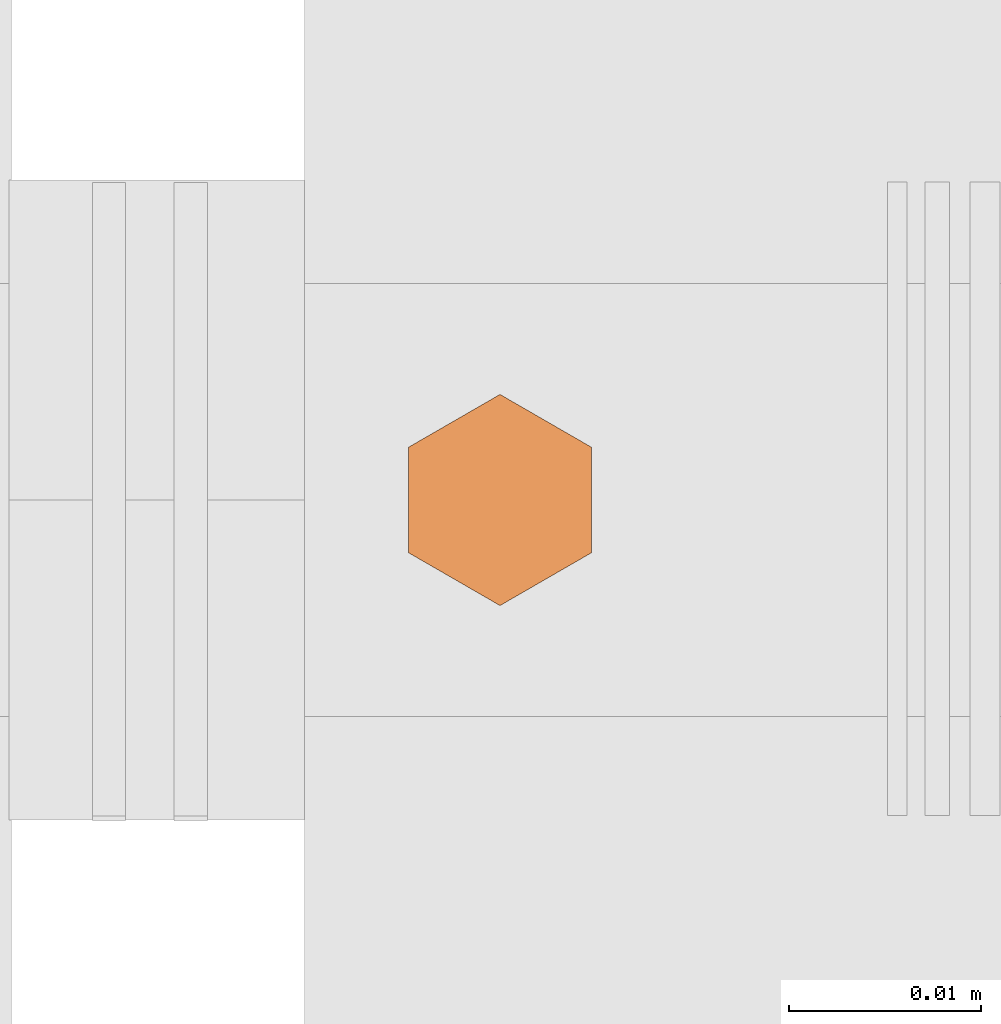
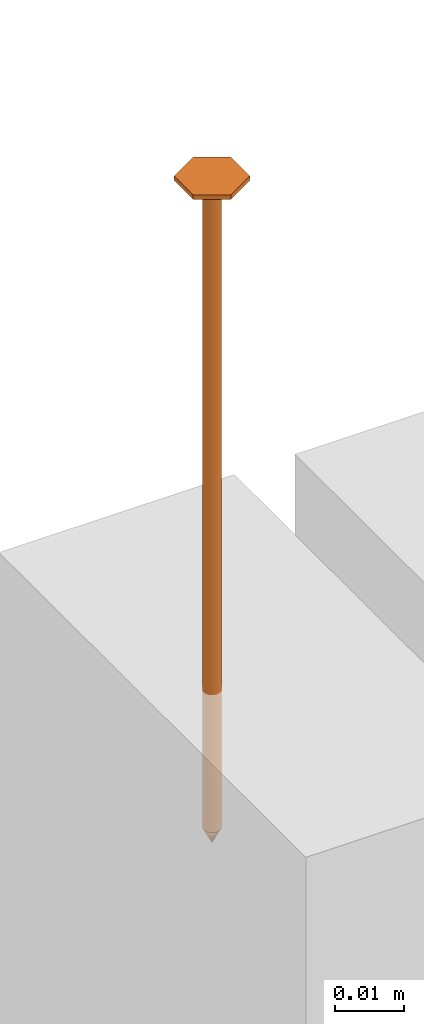
# One storey, part 23 of 44: 1 proxy.
"""IFC4 building model written with IfcOpenShell, lengths in feet."""

from ifc_helpers import new_model, entity, si_unit, converted_unit, derived_unit, direction, frame, origin, place, context, subcontext, project, spatial, source, transform, mapped, material, type_object, type_shapes, element, save


model = new_model("IFC4")

# Units and contexts
model_context = context("Model", 3, precision=0.0001, world=origin(), true_north=direction((6.12303176911189e-17, 1.0)))
body_context = subcontext(model_context, "Body", "Model", "MODEL_VIEW")
ifc_project = project(units=[converted_unit("LENGTHUNIT", "FOOT", entity("IfcRatioMeasure", 0.3048), si_unit("LENGTHUNIT", "METRE"), dimensions=[1, 0, 0, 0, 0, 0, 0]), converted_unit("AREAUNIT", "SQUARE FOOT", entity("IfcRatioMeasure", 0.09290304), si_unit("AREAUNIT", "SQUARE_METRE"), dimensions=[2, 0, 0, 0, 0, 0, 0]), converted_unit("VOLUMEUNIT", "CUBIC FOOT", entity("IfcRatioMeasure", 0.028316846592), si_unit("VOLUMEUNIT", "CUBIC_METRE"), dimensions=[3, 0, 0, 0, 0, 0, 0]), converted_unit("PLANEANGLEUNIT", "DEGREE", entity("IfcRatioMeasure", 0.0174532925199433), si_unit("PLANEANGLEUNIT", "RADIAN"), dimensions=[0, 0, 0, 0, 0, 0, 0]), si_unit("MASSUNIT", "GRAM", prefix="KILO"), derived_unit("MASSDENSITYUNIT", [(si_unit("MASSUNIT", "GRAM", prefix="KILO"), 1), (si_unit("LENGTHUNIT", "METRE"), -3)]), derived_unit("MOMENTOFINERTIAUNIT", [(si_unit("LENGTHUNIT", "METRE"), 4)]), si_unit("TIMEUNIT", "SECOND"), si_unit("FREQUENCYUNIT", "HERTZ"), si_unit("THERMODYNAMICTEMPERATUREUNIT", "DEGREE_CELSIUS"), derived_unit("THERMALTRANSMITTANCEUNIT", [(si_unit("MASSUNIT", "GRAM", prefix="KILO"), 1), (si_unit("THERMODYNAMICTEMPERATUREUNIT", "KELVIN"), -1), (si_unit("TIMEUNIT", "SECOND"), -3)]), derived_unit("VOLUMETRICFLOWRATEUNIT", [(si_unit("LENGTHUNIT", "METRE"), 3), (si_unit("TIMEUNIT", "SECOND"), -1)]), si_unit("ELECTRICCURRENTUNIT", "AMPERE"), si_unit("ELECTRICVOLTAGEUNIT", "VOLT"), si_unit("POWERUNIT", "WATT"), si_unit("FORCEUNIT", "NEWTON"), si_unit("ILLUMINANCEUNIT", "LUX"), si_unit("LUMINOUSFLUXUNIT", "LUMEN"), si_unit("LUMINOUSINTENSITYUNIT", "CANDELA"), derived_unit("USERDEFINED", [(si_unit("MASSUNIT", "GRAM", prefix="KILO"), -1), (si_unit("LENGTHUNIT", "METRE"), -2), (si_unit("TIMEUNIT", "SECOND"), 3), (si_unit("LUMINOUSFLUXUNIT", "LUMEN"), 1)]), derived_unit("LINEARVELOCITYUNIT", [(si_unit("LENGTHUNIT", "METRE"), 1), (si_unit("TIMEUNIT", "SECOND"), -1)]), si_unit("PRESSUREUNIT", "PASCAL"), derived_unit("USERDEFINED", [(si_unit("LENGTHUNIT", "METRE"), -2), (si_unit("MASSUNIT", "GRAM", prefix="KILO"), 1), (si_unit("TIMEUNIT", "SECOND"), -2)]), derived_unit("LINEARFORCEUNIT", [(si_unit("MASSUNIT", "GRAM", prefix="KILO"), 1), (si_unit("LENGTHUNIT", "METRE"), 1), (si_unit("TIMEUNIT", "SECOND"), -2), (si_unit("LENGTHUNIT", "METRE"), -1)]), derived_unit("PLANARFORCEUNIT", [(si_unit("MASSUNIT", "GRAM", prefix="KILO"), 1), (si_unit("LENGTHUNIT", "METRE"), 1), (si_unit("TIMEUNIT", "SECOND"), -2), (si_unit("LENGTHUNIT", "METRE"), -2)])], contexts=[model_context])

# Site, building, storey
site_placement = place(None, origin())
site = spatial("IfcSite", under=ifc_project, at=site_placement, CompositionType="ELEMENT")
building_placement = place(site_placement, origin())
building = spatial("IfcBuilding", under=site, at=building_placement, CompositionType="ELEMENT")
storey_placement = place(building_placement, origin())
storey = spatial("IfcBuildingStorey", under=building, at=storey_placement, CompositionType="ELEMENT", Elevation=0.0)

# Proxy
ifc_material = material(Name="TRIM HEAD SCREWS AT RAILING - EXTERIOR GRADE", Category="Materials")
building_element_proxy_type = type_object("IfcBuildingElementProxyType", PredefinedType="NOTDEFINED", material=ifc_material)
cartesian_point_1 = entity("IfcCartesianPoint", [0.0, 0.00455729166677975, -0.374999999999898])
vertex_point_1 = entity("IfcVertexPoint", cartesian_point_1)
cartesian_point_2 = entity("IfcCartesianPoint", [0.0, 0.0, -0.374999999999898])
vertex_point_2 = entity("IfcVertexPoint", cartesian_point_2)
ifc_direction_1 = entity("IfcDirection", [0.0, -1.0, 0.0])
edge_curve_1 = entity("IfcEdgeCurve", vertex_point_1, vertex_point_2, entity("IfcTrimmedCurve", entity("IfcLine", cartesian_point_1, entity("IfcVector", ifc_direction_1, 1.0)), [cartesian_point_1], [cartesian_point_2], True, "CARTESIAN"), True)
cartesian_point_3 = entity("IfcCartesianPoint", [0.0, -0.00455729166667765, -0.374999999999898])
vertex_point_3 = entity("IfcVertexPoint", cartesian_point_3)
edge_curve_2 = entity("IfcEdgeCurve", vertex_point_2, vertex_point_3, entity("IfcTrimmedCurve", entity("IfcLine", cartesian_point_2, entity("IfcVector", ifc_direction_1, 1.0)), [cartesian_point_2], [cartesian_point_3], True, "CARTESIAN"), True)
ifc_direction_2 = entity("IfcDirection", [0.0, 0.0, 1.0])
edge_curve_3 = entity("IfcEdgeCurve", vertex_point_3, vertex_point_1, entity("IfcTrimmedCurve", entity("IfcCircle", entity("IfcAxis2Placement3D", cartesian_point_2, ifc_direction_2, ifc_direction_1), 0.0045572916667287), [cartesian_point_3], [cartesian_point_1], True, "CARTESIAN"), True)
edge_curve_4 = entity("IfcEdgeCurve", vertex_point_1, vertex_point_3, entity("IfcTrimmedCurve", entity("IfcCircle", entity("IfcAxis2Placement3D", cartesian_point_2, ifc_direction_2, ifc_direction_1), 0.0045572916667287), [cartesian_point_1], [cartesian_point_3], True, "CARTESIAN"), True)
cartesian_point_4 = entity("IfcCartesianPoint", [0.0, 0.0, -0.384114583333])
vertex_point_4 = entity("IfcVertexPoint", cartesian_point_4)
edge_curve_5 = entity("IfcEdgeCurve", vertex_point_4, vertex_point_1, entity("IfcTrimmedCurve", entity("IfcLine", cartesian_point_4, entity("IfcVector", entity("IfcDirection", [0.0, 0.447213595514579, 0.894427190992605]), 1.0)), [cartesian_point_4], [cartesian_point_1], True, "CARTESIAN"), True)
edge_curve_6 = entity("IfcEdgeCurve", vertex_point_3, vertex_point_4, entity("IfcTrimmedCurve", entity("IfcLine", cartesian_point_3, entity("IfcVector", entity("IfcDirection", [0.0, 0.447213595514596, -0.894427190992597]), 1.0)), [cartesian_point_3], [cartesian_point_4], True, "CARTESIAN"), True)
cartesian_point_5 = entity("IfcCartesianPoint", [-0.00455729166669724, 0.0, -0.374999999999898])
cartesian_point_6 = entity("IfcCartesianPoint", [0.0, 0.0, -0.379868851257523])
ifc_direction_3 = entity("IfcDirection", [0.0, 0.0, -1.0])
cartesian_point_7 = entity("IfcCartesianPoint", [-0.0156249999999625, -0.00902109795594613, 0.00260416666704037])
vertex_point_5 = entity("IfcVertexPoint", cartesian_point_7)
cartesian_point_8 = entity("IfcCartesianPoint", [0.0, -0.0180421959120243, 0.00260416666704032])
vertex_point_6 = entity("IfcVertexPoint", cartesian_point_8)
edge_curve_7 = entity("IfcEdgeCurve", vertex_point_5, vertex_point_6, entity("IfcTrimmedCurve", entity("IfcLine", cartesian_point_7, entity("IfcVector", entity("IfcDirection", [0.866025403784438, -0.500000000000001, 0.0]), 1.0)), [cartesian_point_7], [cartesian_point_8], True, "CARTESIAN"), True)
cartesian_point_9 = entity("IfcCartesianPoint", [0.0156250000000786, -0.00902109795590273, 0.00260416666704037])
vertex_point_7 = entity("IfcVertexPoint", cartesian_point_9)
edge_curve_8 = entity("IfcEdgeCurve", vertex_point_6, vertex_point_7, entity("IfcTrimmedCurve", entity("IfcLine", cartesian_point_8, entity("IfcVector", entity("IfcDirection", [0.866025403784437, 0.500000000000003, 0.0]), 1.0)), [cartesian_point_8], [cartesian_point_9], True, "CARTESIAN"), True)
cartesian_point_10 = entity("IfcCartesianPoint", [0.0156250000000786, 0.00902109795620598, 0.00260416666704046])
vertex_point_8 = entity("IfcVertexPoint", cartesian_point_10)
ifc_direction_4 = entity("IfcDirection", [0.0, 1.0, 0.0])
edge_curve_9 = entity("IfcEdgeCurve", vertex_point_7, vertex_point_8, entity("IfcTrimmedCurve", entity("IfcLine", cartesian_point_9, entity("IfcVector", ifc_direction_4, 1.0)), [cartesian_point_9], [cartesian_point_10], True, "CARTESIAN"), True)
cartesian_point_11 = entity("IfcCartesianPoint", [0.0, 0.0180421959123274, 0.0026041666670405])
vertex_point_9 = entity("IfcVertexPoint", cartesian_point_11)
edge_curve_10 = entity("IfcEdgeCurve", vertex_point_8, vertex_point_9, entity("IfcTrimmedCurve", entity("IfcLine", cartesian_point_10, entity("IfcVector", entity("IfcDirection", [-0.86602540378444, 0.499999999999998, 0.0]), 1.0)), [cartesian_point_10], [cartesian_point_11], True, "CARTESIAN"), True)
cartesian_point_12 = entity("IfcCartesianPoint", [-0.0156249999999625, 0.0090210979562493, 0.00260416666704046])
vertex_point_10 = entity("IfcVertexPoint", cartesian_point_12)
edge_curve_11 = entity("IfcEdgeCurve", vertex_point_9, vertex_point_10, entity("IfcTrimmedCurve", entity("IfcLine", cartesian_point_11, entity("IfcVector", entity("IfcDirection", [-0.866025403784438, -0.500000000000001, 0.0]), 1.0)), [cartesian_point_11], [cartesian_point_12], True, "CARTESIAN"), True)
ifc_direction_5 = entity("IfcDirection", [0.0, -1.0, 0.0])
edge_curve_12 = entity("IfcEdgeCurve", vertex_point_10, vertex_point_5, entity("IfcTrimmedCurve", entity("IfcLine", cartesian_point_12, entity("IfcVector", ifc_direction_5, 1.0)), [cartesian_point_12], [cartesian_point_7], True, "CARTESIAN"), True)
ifc_direction_6 = entity("IfcDirection", [0.0, 0.0, 1.0])
cartesian_point_13 = entity("IfcCartesianPoint", [-0.0156249999999625, -0.00902109795594612, 0.0])
vertex_point_11 = entity("IfcVertexPoint", cartesian_point_13)
cartesian_point_14 = entity("IfcCartesianPoint", [-0.0156249999999625, 0.00902109795624931, 0.0])
vertex_point_12 = entity("IfcVertexPoint", cartesian_point_14)
edge_curve_13 = entity("IfcEdgeCurve", vertex_point_11, vertex_point_12, entity("IfcTrimmedCurve", entity("IfcLine", cartesian_point_13, entity("IfcVector", ifc_direction_4, 1.0)), [cartesian_point_13], [cartesian_point_14], True, "CARTESIAN"), True)
cartesian_point_15 = entity("IfcCartesianPoint", [0.0, 0.0180421959123274, 0.0])
vertex_point_13 = entity("IfcVertexPoint", cartesian_point_15)
edge_curve_14 = entity("IfcEdgeCurve", vertex_point_12, vertex_point_13, entity("IfcTrimmedCurve", entity("IfcLine", cartesian_point_14, entity("IfcVector", entity("IfcDirection", [0.866025403784438, 0.500000000000001, 0.0]), 1.0)), [cartesian_point_14], [cartesian_point_15], True, "CARTESIAN"), True)
cartesian_point_16 = entity("IfcCartesianPoint", [0.0156250000000786, 0.00902109795620599, 0.0])
vertex_point_14 = entity("IfcVertexPoint", cartesian_point_16)
edge_curve_15 = entity("IfcEdgeCurve", vertex_point_13, vertex_point_14, entity("IfcTrimmedCurve", entity("IfcLine", cartesian_point_15, entity("IfcVector", entity("IfcDirection", [0.86602540378444, -0.499999999999998, 0.0]), 1.0)), [cartesian_point_15], [cartesian_point_16], True, "CARTESIAN"), True)
cartesian_point_17 = entity("IfcCartesianPoint", [0.0156250000000786, -0.00902109795590272, 0.0])
vertex_point_15 = entity("IfcVertexPoint", cartesian_point_17)
edge_curve_16 = entity("IfcEdgeCurve", vertex_point_14, vertex_point_15, entity("IfcTrimmedCurve", entity("IfcLine", cartesian_point_16, entity("IfcVector", ifc_direction_5, 1.0)), [cartesian_point_16], [cartesian_point_17], True, "CARTESIAN"), True)
cartesian_point_18 = entity("IfcCartesianPoint", [0.0, -0.0180421959120242, 0.0])
vertex_point_16 = entity("IfcVertexPoint", cartesian_point_18)
edge_curve_17 = entity("IfcEdgeCurve", vertex_point_15, vertex_point_16, entity("IfcTrimmedCurve", entity("IfcLine", cartesian_point_17, entity("IfcVector", entity("IfcDirection", [-0.866025403784437, -0.500000000000003, 0.0]), 1.0)), [cartesian_point_17], [cartesian_point_18], True, "CARTESIAN"), True)
edge_curve_18 = entity("IfcEdgeCurve", vertex_point_16, vertex_point_11, entity("IfcTrimmedCurve", entity("IfcLine", cartesian_point_18, entity("IfcVector", entity("IfcDirection", [-0.866025403784438, 0.500000000000001, 0.0]), 1.0)), [cartesian_point_18], [cartesian_point_13], True, "CARTESIAN"), True)
ifc_direction_7 = entity("IfcDirection", [0.0, 0.0, -1.0])
edge_curve_19 = entity("IfcEdgeCurve", vertex_point_10, vertex_point_12, entity("IfcTrimmedCurve", entity("IfcLine", cartesian_point_14, entity("IfcVector", ifc_direction_7, 1.0)), [cartesian_point_12], [cartesian_point_14], True, "CARTESIAN"), True)
edge_curve_20 = entity("IfcEdgeCurve", vertex_point_11, vertex_point_5, entity("IfcTrimmedCurve", entity("IfcLine", cartesian_point_13, entity("IfcVector", ifc_direction_6, 1.0)), [cartesian_point_13], [cartesian_point_7], True, "CARTESIAN"), True)
edge_curve_21 = entity("IfcEdgeCurve", vertex_point_9, vertex_point_13, entity("IfcTrimmedCurve", entity("IfcLine", cartesian_point_15, entity("IfcVector", ifc_direction_7, 1.0)), [cartesian_point_11], [cartesian_point_15], True, "CARTESIAN"), True)
edge_curve_22 = entity("IfcEdgeCurve", vertex_point_8, vertex_point_14, entity("IfcTrimmedCurve", entity("IfcLine", cartesian_point_16, entity("IfcVector", ifc_direction_7, 1.0)), [cartesian_point_10], [cartesian_point_16], True, "CARTESIAN"), True)
edge_curve_23 = entity("IfcEdgeCurve", vertex_point_7, vertex_point_15, entity("IfcTrimmedCurve", entity("IfcLine", cartesian_point_17, entity("IfcVector", ifc_direction_7, 1.0)), [cartesian_point_9], [cartesian_point_17], True, "CARTESIAN"), True)
edge_curve_24 = entity("IfcEdgeCurve", vertex_point_6, vertex_point_16, entity("IfcTrimmedCurve", entity("IfcLine", cartesian_point_18, entity("IfcVector", ifc_direction_7, 1.0)), [cartesian_point_8], [cartesian_point_18], True, "CARTESIAN"), True)
cartesian_point_19 = entity("IfcCartesianPoint", [0.0, 0.00455729166682102, 0.0])
vertex_point_17 = entity("IfcVertexPoint", cartesian_point_19)
cartesian_point_20 = entity("IfcCartesianPoint", [0.0, -0.00455729166651231, 0.0])
vertex_point_18 = entity("IfcVertexPoint", cartesian_point_20)
cartesian_point_21 = entity("IfcCartesianPoint", [0.0, 0.0, 0.0])
ifc_direction_8 = entity("IfcDirection", [0.0, 0.0, 1.0])
ifc_direction_9 = entity("IfcDirection", [0.0, -1.0, 0.0])
edge_curve_25 = entity("IfcEdgeCurve", vertex_point_17, vertex_point_18, entity("IfcTrimmedCurve", entity("IfcCircle", entity("IfcAxis2Placement3D", cartesian_point_21, ifc_direction_8, ifc_direction_9), 0.00455729166666667), [cartesian_point_19], [cartesian_point_20], True, "CARTESIAN"), True)
edge_curve_26 = entity("IfcEdgeCurve", vertex_point_18, vertex_point_17, entity("IfcTrimmedCurve", entity("IfcCircle", entity("IfcAxis2Placement3D", cartesian_point_21, ifc_direction_8, ifc_direction_9), 0.00455729166666667), [cartesian_point_20], [cartesian_point_19], True, "CARTESIAN"), True)
cartesian_point_22 = entity("IfcCartesianPoint", [0.0, 0.00455729166682425, -0.375000000000006])
vertex_point_19 = entity("IfcVertexPoint", cartesian_point_22)
cartesian_point_23 = entity("IfcCartesianPoint", [0.0, -0.00455729166650908, -0.375000000000006])
vertex_point_20 = entity("IfcVertexPoint", cartesian_point_23)
cartesian_point_24 = entity("IfcCartesianPoint", [0.0, 0.0, -0.375000000000006])
ifc_direction_10 = entity("IfcDirection", [0.0, 0.0, -1.0])
edge_curve_27 = entity("IfcEdgeCurve", vertex_point_19, vertex_point_20, entity("IfcTrimmedCurve", entity("IfcCircle", entity("IfcAxis2Placement3D", cartesian_point_24, ifc_direction_10, ifc_direction_9), 0.00455729166666667), [cartesian_point_22], [cartesian_point_23], True, "CARTESIAN"), True)
edge_curve_28 = entity("IfcEdgeCurve", vertex_point_20, vertex_point_19, entity("IfcTrimmedCurve", entity("IfcCircle", entity("IfcAxis2Placement3D", cartesian_point_24, ifc_direction_10, ifc_direction_9), 0.00455729166666667), [cartesian_point_23], [cartesian_point_22], True, "CARTESIAN"), True)
edge_curve_29 = entity("IfcEdgeCurve", vertex_point_18, vertex_point_20, entity("IfcTrimmedCurve", entity("IfcLine", cartesian_point_23, entity("IfcVector", ifc_direction_10, 1.0)), [cartesian_point_20], [cartesian_point_23], True, "CARTESIAN"), True)
edge_curve_30 = entity("IfcEdgeCurve", vertex_point_19, vertex_point_17, entity("IfcTrimmedCurve", entity("IfcLine", cartesian_point_22, entity("IfcVector", ifc_direction_8, 1.0)), [cartesian_point_22], [cartesian_point_19], True, "CARTESIAN"), True)
shared_shape = source(origin(), body_context, "Body", "AdvancedBrep", [
    entity("IfcAdvancedBrep", entity("IfcClosedShell", [entity("IfcAdvancedFace", [entity("IfcFaceOuterBound", entity("IfcEdgeLoop", [entity("IfcOrientedEdge", None, None, edge_curve_1, True), entity("IfcOrientedEdge", None, None, edge_curve_2, True), entity("IfcOrientedEdge", None, None, edge_curve_3, True)]), True)], entity("IfcPlane", entity("IfcAxis2Placement3D", cartesian_point_2, ifc_direction_2, ifc_direction_1)), True), entity("IfcAdvancedFace", [entity("IfcFaceOuterBound", entity("IfcEdgeLoop", [entity("IfcOrientedEdge", None, None, edge_curve_2, False), entity("IfcOrientedEdge", None, None, edge_curve_1, False), entity("IfcOrientedEdge", None, None, edge_curve_4, True)]), True)], entity("IfcPlane", entity("IfcAxis2Placement3D", cartesian_point_2, ifc_direction_2, ifc_direction_1)), True), entity("IfcAdvancedFace", [entity("IfcFaceOuterBound", entity("IfcEdgeLoop", [entity("IfcOrientedEdge", None, None, edge_curve_5, True), entity("IfcOrientedEdge", None, None, edge_curve_3, False), entity("IfcOrientedEdge", None, None, edge_curve_6, True)]), True)], entity("IfcSurfaceOfRevolution", entity("IfcArbitraryOpenProfileDef", "CURVE", None, entity("IfcTrimmedCurve", entity("IfcLine", cartesian_point_4, entity("IfcVector", entity("IfcDirection", [0.447213595514577, 0.0, -0.894427190992606]), 1.0)), [cartesian_point_5], [cartesian_point_4], True, "CARTESIAN")), None, entity("IfcAxis1Placement", cartesian_point_6, ifc_direction_3)), True), entity("IfcAdvancedFace", [entity("IfcFaceOuterBound", entity("IfcEdgeLoop", [entity("IfcOrientedEdge", None, None, edge_curve_6, False), entity("IfcOrientedEdge", None, None, edge_curve_4, False), entity("IfcOrientedEdge", None, None, edge_curve_5, False)]), True)], entity("IfcSurfaceOfRevolution", entity("IfcArbitraryOpenProfileDef", "CURVE", None, entity("IfcTrimmedCurve", entity("IfcLine", cartesian_point_4, entity("IfcVector", entity("IfcDirection", [0.447213595514577, 0.0, -0.894427190992606]), 1.0)), [cartesian_point_5], [cartesian_point_4], True, "CARTESIAN")), None, entity("IfcAxis1Placement", cartesian_point_6, ifc_direction_3)), True)])),
    entity("IfcAdvancedBrep", entity("IfcClosedShell", [entity("IfcAdvancedFace", [entity("IfcFaceOuterBound", entity("IfcEdgeLoop", [entity("IfcOrientedEdge", None, None, edge_curve_7, True), entity("IfcOrientedEdge", None, None, edge_curve_8, True), entity("IfcOrientedEdge", None, None, edge_curve_9, True), entity("IfcOrientedEdge", None, None, edge_curve_10, True), entity("IfcOrientedEdge", None, None, edge_curve_11, True), entity("IfcOrientedEdge", None, None, edge_curve_12, True)]), True)], entity("IfcPlane", entity("IfcAxis2Placement3D", cartesian_point_7, ifc_direction_6, ifc_direction_4)), True), entity("IfcAdvancedFace", [entity("IfcFaceOuterBound", entity("IfcEdgeLoop", [entity("IfcOrientedEdge", None, None, edge_curve_13, True), entity("IfcOrientedEdge", None, None, edge_curve_14, True), entity("IfcOrientedEdge", None, None, edge_curve_15, True), entity("IfcOrientedEdge", None, None, edge_curve_16, True), entity("IfcOrientedEdge", None, None, edge_curve_17, True), entity("IfcOrientedEdge", None, None, edge_curve_18, True)]), True)], entity("IfcPlane", entity("IfcAxis2Placement3D", cartesian_point_13, ifc_direction_7, ifc_direction_5)), True), entity("IfcAdvancedFace", [entity("IfcFaceOuterBound", entity("IfcEdgeLoop", [entity("IfcOrientedEdge", None, None, edge_curve_19, True), entity("IfcOrientedEdge", None, None, edge_curve_13, False), entity("IfcOrientedEdge", None, None, edge_curve_20, True), entity("IfcOrientedEdge", None, None, edge_curve_12, False)]), True)], entity("IfcPlane", entity("IfcAxis2Placement3D", cartesian_point_7, entity("IfcDirection", [-1.0, 0.0, 0.0]), ifc_direction_7)), True), entity("IfcAdvancedFace", [entity("IfcFaceOuterBound", entity("IfcEdgeLoop", [entity("IfcOrientedEdge", None, None, edge_curve_21, True), entity("IfcOrientedEdge", None, None, edge_curve_14, False), entity("IfcOrientedEdge", None, None, edge_curve_19, False), entity("IfcOrientedEdge", None, None, edge_curve_11, False)]), True)], entity("IfcPlane", entity("IfcAxis2Placement3D", cartesian_point_12, entity("IfcDirection", [-0.500000000000001, 0.866025403784438, 0.0]), ifc_direction_7)), True), entity("IfcAdvancedFace", [entity("IfcFaceOuterBound", entity("IfcEdgeLoop", [entity("IfcOrientedEdge", None, None, edge_curve_22, True), entity("IfcOrientedEdge", None, None, edge_curve_15, False), entity("IfcOrientedEdge", None, None, edge_curve_21, False), entity("IfcOrientedEdge", None, None, edge_curve_10, False)]), True)], entity("IfcPlane", entity("IfcAxis2Placement3D", cartesian_point_11, entity("IfcDirection", [0.499999999999998, 0.86602540378444, 0.0]), ifc_direction_7)), True), entity("IfcAdvancedFace", [entity("IfcFaceOuterBound", entity("IfcEdgeLoop", [entity("IfcOrientedEdge", None, None, edge_curve_23, True), entity("IfcOrientedEdge", None, None, edge_curve_16, False), entity("IfcOrientedEdge", None, None, edge_curve_22, False), entity("IfcOrientedEdge", None, None, edge_curve_9, False)]), True)], entity("IfcPlane", entity("IfcAxis2Placement3D", cartesian_point_10, entity("IfcDirection", [1.0, 0.0, 0.0]), ifc_direction_7)), True), entity("IfcAdvancedFace", [entity("IfcFaceOuterBound", entity("IfcEdgeLoop", [entity("IfcOrientedEdge", None, None, edge_curve_24, True), entity("IfcOrientedEdge", None, None, edge_curve_17, False), entity("IfcOrientedEdge", None, None, edge_curve_23, False), entity("IfcOrientedEdge", None, None, edge_curve_8, False)]), True)], entity("IfcPlane", entity("IfcAxis2Placement3D", cartesian_point_9, entity("IfcDirection", [0.500000000000003, -0.866025403784437, 0.0]), ifc_direction_7)), True), entity("IfcAdvancedFace", [entity("IfcFaceOuterBound", entity("IfcEdgeLoop", [entity("IfcOrientedEdge", None, None, edge_curve_20, False), entity("IfcOrientedEdge", None, None, edge_curve_18, False), entity("IfcOrientedEdge", None, None, edge_curve_24, False), entity("IfcOrientedEdge", None, None, edge_curve_7, False)]), True)], entity("IfcPlane", entity("IfcAxis2Placement3D", cartesian_point_8, entity("IfcDirection", [-0.500000000000001, -0.866025403784438, 0.0]), ifc_direction_7)), True)])),
    entity("IfcAdvancedBrep", entity("IfcClosedShell", [entity("IfcAdvancedFace", [entity("IfcFaceOuterBound", entity("IfcEdgeLoop", [entity("IfcOrientedEdge", None, None, edge_curve_25, True), entity("IfcOrientedEdge", None, None, edge_curve_26, True)]), True)], entity("IfcPlane", entity("IfcAxis2Placement3D", cartesian_point_20, ifc_direction_8, entity("IfcDirection", [-1.0, 0.0, 0.0]))), True), entity("IfcAdvancedFace", [entity("IfcFaceOuterBound", entity("IfcEdgeLoop", [entity("IfcOrientedEdge", None, None, edge_curve_27, True), entity("IfcOrientedEdge", None, None, edge_curve_28, True)]), True)], entity("IfcPlane", entity("IfcAxis2Placement3D", cartesian_point_23, ifc_direction_10, entity("IfcDirection", [1.0, 0.0, 0.0]))), True), entity("IfcAdvancedFace", [entity("IfcFaceOuterBound", entity("IfcEdgeLoop", [entity("IfcOrientedEdge", None, None, edge_curve_29, True), entity("IfcOrientedEdge", None, None, edge_curve_27, False), entity("IfcOrientedEdge", None, None, edge_curve_30, True), entity("IfcOrientedEdge", None, None, edge_curve_26, False)]), True)], entity("IfcCylindricalSurface", entity("IfcAxis2Placement3D", cartesian_point_24, ifc_direction_8, ifc_direction_9), 0.00455729166666667), True), entity("IfcAdvancedFace", [entity("IfcFaceOuterBound", entity("IfcEdgeLoop", [entity("IfcOrientedEdge", None, None, edge_curve_30, False), entity("IfcOrientedEdge", None, None, edge_curve_28, False), entity("IfcOrientedEdge", None, None, edge_curve_29, False), entity("IfcOrientedEdge", None, None, edge_curve_25, False)]), True)], entity("IfcCylindricalSurface", entity("IfcAxis2Placement3D", cartesian_point_24, ifc_direction_8, ifc_direction_9), 0.00455729166666667), True)])),
])
type_shapes(building_element_proxy_type, [shared_shape])
proxy_placement = place(storey_placement, frame((1494.37573162332, 4.90491114741337, 14.1770833333334), z_axis=(0.0, 0.0, 1.0), x_axis=(-1.0, 0.0, 0.0)))
element("IfcBuildingElementProxy", 1, at=proxy_placement, inside=storey, type_object=building_element_proxy_type, material=ifc_material, PredefinedType="NOTDEFINED", context=body_context, shape_type="MappedRepresentation", body=[
    mapped(shared_shape, transform((0.0, 0.0, 0.0), scale=1.0)),
])

save(model, "model.ifc")
